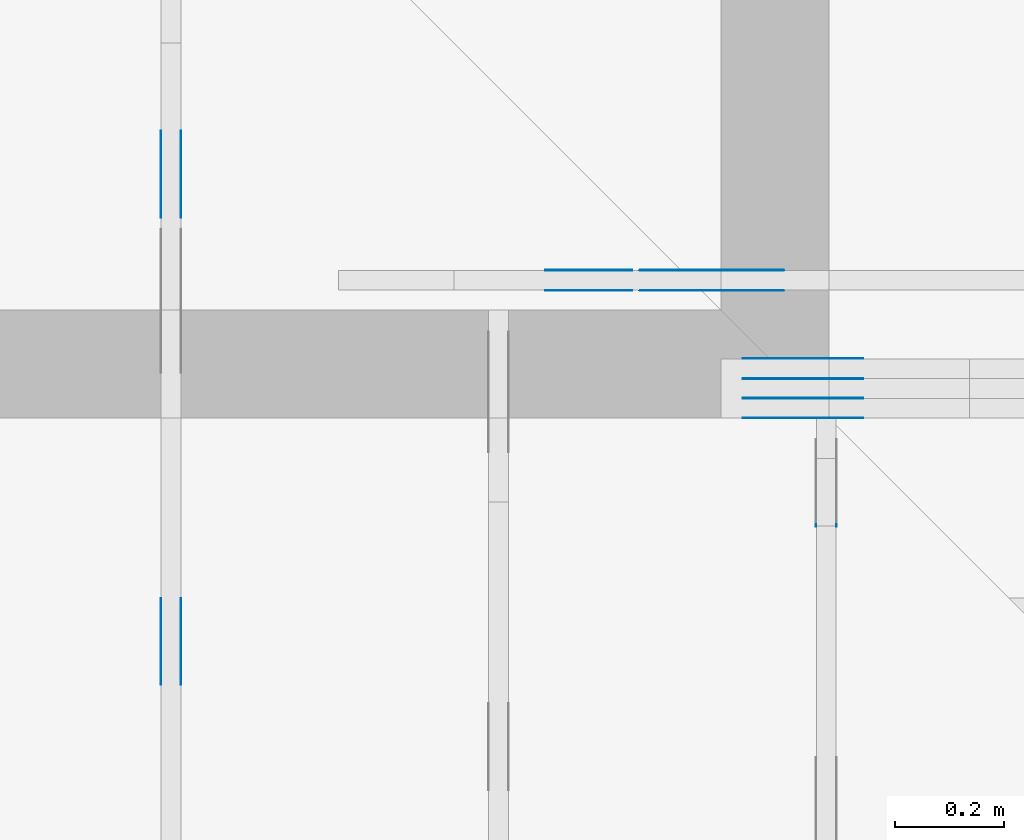
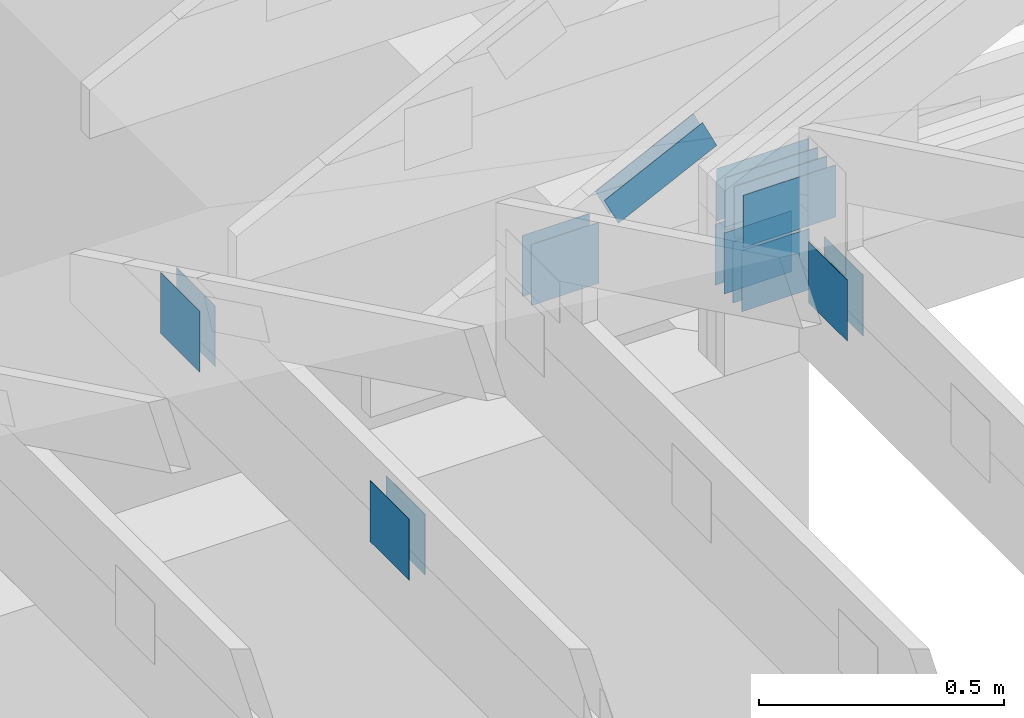
# One storey, part 97 of 159: 22 plates, 4 elements without a shape of their own.
"""IFC2X3 building model written with IfcOpenShell, lengths in millimetres."""

from ifc_helpers import new_model, si_unit, frame, origin, origin_with_axes, origin_2d, place, context, project, spatial, faceted_brep, element, aggregate, save


model = new_model("IFC2X3")

# Units and contexts
model_context = context("Model", 3, precision=1e-05, world=origin())
plan_context = context("Plan", 2, precision=1e-05, world=origin_2d())
ifc_project = project(units=[si_unit("LENGTHUNIT", "METRE", prefix="MILLI"), si_unit("AREAUNIT", "SQUARE_METRE"), si_unit("VOLUMEUNIT", "CUBIC_METRE"), si_unit("SOLIDANGLEUNIT", "STERADIAN"), si_unit("PLANEANGLEUNIT", "RADIAN"), si_unit("MASSUNIT", "GRAM"), si_unit("TIMEUNIT", "SECOND"), si_unit("THERMODYNAMICTEMPERATUREUNIT", "DEGREE_CELSIUS"), si_unit("LUMINOUSINTENSITYUNIT", "LUMEN")], contexts=[model_context, plan_context])

# Site, building, storey
site_placement = place(None, origin_with_axes())
site = spatial("IfcSite", under=ifc_project, at=site_placement, CompositionType="ELEMENT")
building_placement = place(site_placement, origin_with_axes())
building = spatial("IfcBuilding", under=site, at=building_placement, Name="Plan 1", CompositionType="ELEMENT")
storey_placement = place(building_placement, origin_with_axes())
storey = spatial("IfcBuildingStorey", under=building, at=storey_placement, Name="Etasje 1", CompositionType="ELEMENT", Elevation=0.0)

# Assembly, plates
assembly_1_placement = place(storey_placement, frame((10700.012663101485, 8801.999999990367, 0.0), z_axis=(0.0, -1.0, 6.123031769111886e-17), x_axis=(1.0, 0.0, 0.0)))
assembly_1 = element("IfcElementAssembly", 1, at=assembly_1_placement, inside=storey, Name="T8 (1)", AssemblyPlace="FACTORY", PredefinedType="TRUSS")
plate_1_placement = place(assembly_1_placement, frame((43.239723205566406, 306.0, 0.0), z_axis=(0.0, 0.0, 1.0), x_axis=(1.0, 0.0, 0.0)))
plate_1 = element("IfcPlate", 2, at=plate_1_placement, Name="GNT100S 130x218", context=model_context, shape_type="Brep", body=[
    faceted_brep([(217.99999237060547, 130.0, 1.0), (0.0, 130.0, 1.0), (0.0, 0.0, 1.0), (217.99999237060547, 0.0, 1.0), (0.0, 130.0, 0.0), (217.99999237060547, 130.0, 2.6696417579027322e-14), (217.99999237060547, 0.0, 2.6696417579027322e-14), (0.0, 0.0, 0.0), (218.00000187195837, 1.304856284685705e-13, 2.451945301233962e-30), (218.00000187195837, 1.305468587862616e-13, 1.0), (1.8719583749771118e-06, 1.7059148655625335e-13, 1.0), (1.8719583749771118e-06, 1.7053025623856223e-13, 2.1054768666696277e-38), (218.00000187195837, 130.00000000000017, 0.0), (218.00000187195837, 130.00000000000017, 1.0), (218.00000187195837, 1.7053025658242404e-13, 1.0), (218.00000187195837, 1.7053025658242404e-13, 0.0), (1.8719583749771118e-06, 130.00000000000017, 0.0), (1.8719583749771118e-06, 130.00000000000017, 1.0), (218.00000187195837, 130.00000000000017, 1.0), (218.00000187195837, 130.00000000000017, -1.5777218104420236e-30), (1.8719583749771118e-06, 1.7053025658242404e-13, 0.0), (1.8719583750383421e-06, 1.7053025658242404e-13, 1.0), (1.8719583909582247e-06, 130.00000000000017, 1.0), (1.8719583908969944e-06, 130.00000000000017, -9.747794662456535e-31)], [[[0, 1, 2, 3]], [[4, 5, 6, 7]], [[8, 9, 10, 11]], [[12, 13, 14, 15]], [[16, 17, 18, 19]], [[20, 21, 22, 23]]]),
])
plate_2_placement = place(assembly_1_placement, frame((43.239723205566406, 306.0, -37.0), z_axis=(0.0, 0.0, 1.0), x_axis=(1.0, 0.0, 0.0)))
plate_2 = element("IfcPlate", 3, at=plate_2_placement, Name="GNT100S 130x218", context=model_context, shape_type="Brep", body=[
    faceted_brep([(217.99999237060547, 130.0, 1.0), (0.0, 130.0, 1.0), (0.0, 0.0, 1.0), (217.99999237060547, 0.0, 1.0), (0.0, 130.0, 0.0), (217.99999237060547, 130.0, 2.6696417579027322e-14), (217.99999237060547, 0.0, 2.6696417579027322e-14), (0.0, 0.0, 0.0), (218.00000187195837, 1.304856284685705e-13, 2.451945301233962e-30), (218.00000187195837, 1.305468587862616e-13, 1.0), (1.8719583749771118e-06, 1.7059148655625335e-13, 1.0), (1.8719583749771118e-06, 1.7053025623856223e-13, 2.1054768666696277e-38), (218.00000187195837, 130.00000000000017, 0.0), (218.00000187195837, 130.00000000000017, 1.0), (218.00000187195837, 1.7053025658242404e-13, 1.0), (218.00000187195837, 1.7053025658242404e-13, 0.0), (1.8719583749771118e-06, 130.00000000000017, 0.0), (1.8719583749771118e-06, 130.00000000000017, 1.0), (218.00000187195837, 130.00000000000017, 1.0), (218.00000187195837, 130.00000000000017, -1.5777218104420236e-30), (1.8719583749771118e-06, 1.7053025658242404e-13, 0.0), (1.8719583750383421e-06, 1.7053025658242404e-13, 1.0), (1.8719583909582247e-06, 130.00000000000017, 1.0), (1.8719583908969944e-06, 130.00000000000017, -9.747794662456535e-31)], [[[0, 1, 2, 3]], [[4, 5, 6, 7]], [[8, 9, 10, 11]], [[12, 13, 14, 15]], [[16, 17, 18, 19]], [[20, 21, 22, 23]]]),
])
plate_3_placement = place(assembly_1_placement, frame((43.239723205566406, 306.0, -36.0), z_axis=(0.0, 0.0, 1.0), x_axis=(1.0, 0.0, 0.0)))
plate_3 = element("IfcPlate", 4, at=plate_3_placement, Name="GNT100S 130x218", context=model_context, shape_type="Brep", body=[
    faceted_brep([(217.99999237060547, 130.0, 1.0), (0.0, 130.0, 1.0), (0.0, 0.0, 1.0), (217.99999237060547, 0.0, 1.0), (0.0, 130.0, 0.0), (217.99999237060547, 130.0, 2.6696417579027322e-14), (217.99999237060547, 0.0, 2.6696417579027322e-14), (0.0, 0.0, 0.0), (218.00000187195837, 1.304856284685705e-13, 2.451945301233962e-30), (218.00000187195837, 1.305468587862616e-13, 1.0), (1.8719583749771118e-06, 1.7059148655625335e-13, 1.0), (1.8719583749771118e-06, 1.7053025623856223e-13, 2.1054768666696277e-38), (218.00000187195837, 130.00000000000017, 0.0), (218.00000187195837, 130.00000000000017, 1.0), (218.00000187195837, 1.7053025658242404e-13, 1.0), (218.00000187195837, 1.7053025658242404e-13, 0.0), (1.8719583749771118e-06, 130.00000000000017, 0.0), (1.8719583749771118e-06, 130.00000000000017, 1.0), (218.00000187195837, 130.00000000000017, 1.0), (218.00000187195837, 130.00000000000017, -1.5777218104420236e-30), (1.8719583749771118e-06, 1.7053025658242404e-13, 0.0), (1.8719583750383421e-06, 1.7053025658242404e-13, 1.0), (1.8719583909582247e-06, 130.00000000000017, 1.0), (1.8719583908969944e-06, 130.00000000000017, -9.747794662456535e-31)], [[[0, 1, 2, 3]], [[4, 5, 6, 7]], [[8, 9, 10, 11]], [[12, 13, 14, 15]], [[16, 17, 18, 19]], [[20, 21, 22, 23]]]),
])
plate_4_placement = place(assembly_1_placement, frame((43.239723205566406, 306.0, -73.0), z_axis=(0.0, 0.0, 1.0), x_axis=(1.0, 0.0, 0.0)))
plate_4 = element("IfcPlate", 5, at=plate_4_placement, Name="GNT100S 130x218", context=model_context, shape_type="Brep", body=[
    faceted_brep([(217.99999237060547, 130.0, 1.0), (0.0, 130.0, 1.0), (0.0, 0.0, 1.0), (217.99999237060547, 0.0, 1.0), (0.0, 130.0, 0.0), (217.99999237060547, 130.0, 2.6696417579027322e-14), (217.99999237060547, 0.0, 2.6696417579027322e-14), (0.0, 0.0, 0.0), (218.00000187195837, 1.304856284685705e-13, 2.451945301233962e-30), (218.00000187195837, 1.305468587862616e-13, 1.0), (1.8719583749771118e-06, 1.7059148655625335e-13, 1.0), (1.8719583749771118e-06, 1.7053025623856223e-13, 2.1054768666696277e-38), (218.00000187195837, 130.00000000000017, 0.0), (218.00000187195837, 130.00000000000017, 1.0), (218.00000187195837, 1.7053025658242404e-13, 1.0), (218.00000187195837, 1.7053025658242404e-13, 0.0), (1.8719583749771118e-06, 130.00000000000017, 0.0), (1.8719583749771118e-06, 130.00000000000017, 1.0), (218.00000187195837, 130.00000000000017, 1.0), (218.00000187195837, 130.00000000000017, -1.5777218104420236e-30), (1.8719583749771118e-06, 1.7053025658242404e-13, 0.0), (1.8719583750383421e-06, 1.7053025658242404e-13, 1.0), (1.8719583909582247e-06, 130.00000000000017, 1.0), (1.8719583908969944e-06, 130.00000000000017, -9.747794662456535e-31)], [[[0, 1, 2, 3]], [[4, 5, 6, 7]], [[8, 9, 10, 11]], [[12, 13, 14, 15]], [[16, 17, 18, 19]], [[20, 21, 22, 23]]]),
])
plate_5_placement = place(assembly_1_placement, frame((43.239723205566406, 306.0, -72.0), z_axis=(0.0, 0.0, 1.0), x_axis=(1.0, 0.0, 0.0)))
plate_5 = element("IfcPlate", 6, at=plate_5_placement, Name="GNT100S 130x218", context=model_context, shape_type="Brep", body=[
    faceted_brep([(217.99999237060547, 130.0, 1.0), (0.0, 130.0, 1.0), (0.0, 0.0, 1.0), (217.99999237060547, 0.0, 1.0), (0.0, 130.0, 0.0), (217.99999237060547, 130.0, 2.6696417579027322e-14), (217.99999237060547, 0.0, 2.6696417579027322e-14), (0.0, 0.0, 0.0), (218.00000187195837, 1.304856284685705e-13, 2.451945301233962e-30), (218.00000187195837, 1.305468587862616e-13, 1.0), (1.8719583749771118e-06, 1.7059148655625335e-13, 1.0), (1.8719583749771118e-06, 1.7053025623856223e-13, 2.1054768666696277e-38), (218.00000187195837, 130.00000000000017, 0.0), (218.00000187195837, 130.00000000000017, 1.0), (218.00000187195837, 1.7053025658242404e-13, 1.0), (218.00000187195837, 1.7053025658242404e-13, 0.0), (1.8719583749771118e-06, 130.00000000000017, 0.0), (1.8719583749771118e-06, 130.00000000000017, 1.0), (218.00000187195837, 130.00000000000017, 1.0), (218.00000187195837, 130.00000000000017, -1.5777218104420236e-30), (1.8719583749771118e-06, 1.7053025658242404e-13, 0.0), (1.8719583750383421e-06, 1.7053025658242404e-13, 1.0), (1.8719583909582247e-06, 130.00000000000017, 1.0), (1.8719583908969944e-06, 130.00000000000017, -9.747794662456535e-31)], [[[0, 1, 2, 3]], [[4, 5, 6, 7]], [[8, 9, 10, 11]], [[12, 13, 14, 15]], [[16, 17, 18, 19]], [[20, 21, 22, 23]]]),
])
plate_6_placement = place(assembly_1_placement, frame((43.239723205566406, 306.0, -109.0), z_axis=(0.0, 0.0, 1.0), x_axis=(1.0, 0.0, 0.0)))
plate_6 = element("IfcPlate", 7, at=plate_6_placement, Name="GNT100S 130x218", context=model_context, shape_type="Brep", body=[
    faceted_brep([(217.99999237060547, 130.0, 1.0), (0.0, 130.0, 1.0), (0.0, 0.0, 1.0), (217.99999237060547, 0.0, 1.0), (0.0, 130.0, 0.0), (217.99999237060547, 130.0, 2.6696417579027322e-14), (217.99999237060547, 0.0, 2.6696417579027322e-14), (0.0, 0.0, 0.0), (218.00000187195837, 1.304856284685705e-13, 2.451945301233962e-30), (218.00000187195837, 1.305468587862616e-13, 1.0), (1.8719583749771118e-06, 1.7059148655625335e-13, 1.0), (1.8719583749771118e-06, 1.7053025623856223e-13, 2.1054768666696277e-38), (218.00000187195837, 130.00000000000017, 0.0), (218.00000187195837, 130.00000000000017, 1.0), (218.00000187195837, 1.7053025658242404e-13, 1.0), (218.00000187195837, 1.7053025658242404e-13, 0.0), (1.8719583749771118e-06, 130.00000000000017, 0.0), (1.8719583749771118e-06, 130.00000000000017, 1.0), (218.00000187195837, 130.00000000000017, 1.0), (218.00000187195837, 130.00000000000017, -1.5777218104420236e-30), (1.8719583749771118e-06, 1.7053025658242404e-13, 0.0), (1.8719583750383421e-06, 1.7053025658242404e-13, 1.0), (1.8719583909582247e-06, 130.00000000000017, 1.0), (1.8719583908969944e-06, 130.00000000000017, -9.747794662456535e-31)], [[[0, 1, 2, 3]], [[4, 5, 6, 7]], [[8, 9, 10, 11]], [[12, 13, 14, 15]], [[16, 17, 18, 19]], [[20, 21, 22, 23]]]),
])
plate_7_placement = place(assembly_1_placement, frame((40.0, 147.0, 0.0), z_axis=(0.0, 0.0, 1.0), x_axis=(1.0, 0.0, 0.0)))
plate_7 = element("IfcPlate", 8, at=plate_7_placement, Name="GNT100S 152x159", context=model_context, shape_type="Brep", body=[
    faceted_brep([(159.0, 152.0, 1.0), (0.0, 152.0, 1.0), (0.0, 0.0, 1.0), (159.0, 0.0, 1.0), (0.0, 152.0, 0.0), (159.0, 152.0, 1.9471241025775798e-14), (159.0, 0.0, 1.9471241025775798e-14), (0.0, 0.0, 0.0), (159.0, -2.92068615386637e-14, 1.788345410772899e-30), (159.0, -2.914563122097258e-14, 1.0), (1.1247455413666031e-32, 6.123031769111886e-17, 1.0), (0.0, 0.0, 0.0), (159.0, 152.0, 0.0), (159.0, 152.0, 1.0), (159.0, 0.0, 1.0), (159.0, 0.0, 0.0), (0.0, 152.0, 0.0), (-3.7491518045553436e-33, 152.0, 1.0), (159.0, 152.0, 1.0), (159.0, 152.0, 0.0), (0.0, 0.0, 0.0), (6.123031769111886e-17, -7.498303609110687e-33, 1.0), (1.8675246895791253e-14, 152.0, 1.0), (1.8614016578100134e-14, 152.0, -1.1397421485848245e-30)], [[[0, 1, 2, 3]], [[4, 5, 6, 7]], [[8, 9, 10, 11]], [[12, 13, 14, 15]], [[16, 17, 18, 19]], [[20, 21, 22, 23]]]),
])
plate_8_placement = place(assembly_1_placement, frame((40.0, 147.0, -37.0), z_axis=(0.0, 0.0, 1.0), x_axis=(1.0, 0.0, 0.0)))
plate_8 = element("IfcPlate", 9, at=plate_8_placement, Name="GNT100S 152x159", context=model_context, shape_type="Brep", body=[
    faceted_brep([(159.0, 152.0, 1.0), (0.0, 152.0, 1.0), (0.0, 0.0, 1.0), (159.0, 0.0, 1.0), (0.0, 152.0, 0.0), (159.0, 152.0, 1.9471241025775798e-14), (159.0, 0.0, 1.9471241025775798e-14), (0.0, 0.0, 0.0), (159.0, -2.92068615386637e-14, 1.788345410772899e-30), (159.0, -2.914563122097258e-14, 1.0), (1.1247455413666031e-32, 6.123031769111886e-17, 1.0), (0.0, 0.0, 0.0), (159.0, 152.0, 0.0), (159.0, 152.0, 1.0), (159.0, 0.0, 1.0), (159.0, 0.0, 0.0), (0.0, 152.0, 0.0), (-3.7491518045553436e-33, 152.0, 1.0), (159.0, 152.0, 1.0), (159.0, 152.0, 0.0), (0.0, 0.0, 0.0), (6.123031769111886e-17, -7.498303609110687e-33, 1.0), (1.8675246895791253e-14, 152.0, 1.0), (1.8614016578100134e-14, 152.0, -1.1397421485848245e-30)], [[[0, 1, 2, 3]], [[4, 5, 6, 7]], [[8, 9, 10, 11]], [[12, 13, 14, 15]], [[16, 17, 18, 19]], [[20, 21, 22, 23]]]),
])
plate_9_placement = place(assembly_1_placement, frame((40.0, 147.0, -36.0), z_axis=(0.0, 0.0, 1.0), x_axis=(1.0, 0.0, 0.0)))
plate_9 = element("IfcPlate", 10, at=plate_9_placement, Name="GNT100S 152x159", context=model_context, shape_type="Brep", body=[
    faceted_brep([(159.0, 152.0, 1.0), (0.0, 152.0, 1.0), (0.0, 0.0, 1.0), (159.0, 0.0, 1.0), (0.0, 152.0, 0.0), (159.0, 152.0, 1.9471241025775798e-14), (159.0, 0.0, 1.9471241025775798e-14), (0.0, 0.0, 0.0), (159.0, -2.92068615386637e-14, 1.788345410772899e-30), (159.0, -2.914563122097258e-14, 1.0), (1.1247455413666031e-32, 6.123031769111886e-17, 1.0), (0.0, 0.0, 0.0), (159.0, 152.0, 0.0), (159.0, 152.0, 1.0), (159.0, 0.0, 1.0), (159.0, 0.0, 0.0), (0.0, 152.0, 0.0), (-3.7491518045553436e-33, 152.0, 1.0), (159.0, 152.0, 1.0), (159.0, 152.0, 0.0), (0.0, 0.0, 0.0), (6.123031769111886e-17, -7.498303609110687e-33, 1.0), (1.8675246895791253e-14, 152.0, 1.0), (1.8614016578100134e-14, 152.0, -1.1397421485848245e-30)], [[[0, 1, 2, 3]], [[4, 5, 6, 7]], [[8, 9, 10, 11]], [[12, 13, 14, 15]], [[16, 17, 18, 19]], [[20, 21, 22, 23]]]),
])
plate_10_placement = place(assembly_1_placement, frame((40.0, 147.0, -73.0), z_axis=(0.0, 0.0, 1.0), x_axis=(1.0, 0.0, 0.0)))
plate_10 = element("IfcPlate", 11, at=plate_10_placement, Name="GNT100S 152x159", context=model_context, shape_type="Brep", body=[
    faceted_brep([(159.0, 152.0, 1.0), (0.0, 152.0, 1.0), (0.0, 0.0, 1.0), (159.0, 0.0, 1.0), (0.0, 152.0, 0.0), (159.0, 152.0, 1.9471241025775798e-14), (159.0, 0.0, 1.9471241025775798e-14), (0.0, 0.0, 0.0), (159.0, -2.92068615386637e-14, 1.788345410772899e-30), (159.0, -2.914563122097258e-14, 1.0), (1.1247455413666031e-32, 6.123031769111886e-17, 1.0), (0.0, 0.0, 0.0), (159.0, 152.0, 0.0), (159.0, 152.0, 1.0), (159.0, 0.0, 1.0), (159.0, 0.0, 0.0), (0.0, 152.0, 0.0), (-3.7491518045553436e-33, 152.0, 1.0), (159.0, 152.0, 1.0), (159.0, 152.0, 0.0), (0.0, 0.0, 0.0), (6.123031769111886e-17, -7.498303609110687e-33, 1.0), (1.8675246895791253e-14, 152.0, 1.0), (1.8614016578100134e-14, 152.0, -1.1397421485848245e-30)], [[[0, 1, 2, 3]], [[4, 5, 6, 7]], [[8, 9, 10, 11]], [[12, 13, 14, 15]], [[16, 17, 18, 19]], [[20, 21, 22, 23]]]),
])
plate_11_placement = place(assembly_1_placement, frame((40.0, 147.0, -72.0), z_axis=(0.0, 0.0, 1.0), x_axis=(1.0, 0.0, 0.0)))
plate_11 = element("IfcPlate", 12, at=plate_11_placement, Name="GNT100S 152x159", context=model_context, shape_type="Brep", body=[
    faceted_brep([(159.0, 152.0, 1.0), (0.0, 152.0, 1.0), (0.0, 0.0, 1.0), (159.0, 0.0, 1.0), (0.0, 152.0, 0.0), (159.0, 152.0, 1.9471241025775798e-14), (159.0, 0.0, 1.9471241025775798e-14), (0.0, 0.0, 0.0), (159.0, -2.92068615386637e-14, 1.788345410772899e-30), (159.0, -2.914563122097258e-14, 1.0), (1.1247455413666031e-32, 6.123031769111886e-17, 1.0), (0.0, 0.0, 0.0), (159.0, 152.0, 0.0), (159.0, 152.0, 1.0), (159.0, 0.0, 1.0), (159.0, 0.0, 0.0), (0.0, 152.0, 0.0), (-3.7491518045553436e-33, 152.0, 1.0), (159.0, 152.0, 1.0), (159.0, 152.0, 0.0), (0.0, 0.0, 0.0), (6.123031769111886e-17, -7.498303609110687e-33, 1.0), (1.8675246895791253e-14, 152.0, 1.0), (1.8614016578100134e-14, 152.0, -1.1397421485848245e-30)], [[[0, 1, 2, 3]], [[4, 5, 6, 7]], [[8, 9, 10, 11]], [[12, 13, 14, 15]], [[16, 17, 18, 19]], [[20, 21, 22, 23]]]),
])
plate_12_placement = place(assembly_1_placement, frame((40.0, 147.0, -109.0), z_axis=(0.0, 0.0, 1.0), x_axis=(1.0, 0.0, 0.0)))
plate_12 = element("IfcPlate", 13, at=plate_12_placement, Name="GNT100S 152x159", context=model_context, shape_type="Brep", body=[
    faceted_brep([(159.0, 152.0, 1.0), (0.0, 152.0, 1.0), (0.0, 0.0, 1.0), (159.0, 0.0, 1.0), (0.0, 152.0, 0.0), (159.0, 152.0, 1.9471241025775798e-14), (159.0, 0.0, 1.9471241025775798e-14), (0.0, 0.0, 0.0), (159.0, -2.92068615386637e-14, 1.788345410772899e-30), (159.0, -2.914563122097258e-14, 1.0), (1.1247455413666031e-32, 6.123031769111886e-17, 1.0), (0.0, 0.0, 0.0), (159.0, 152.0, 0.0), (159.0, 152.0, 1.0), (159.0, 0.0, 1.0), (159.0, 0.0, 0.0), (0.0, 152.0, 0.0), (-3.7491518045553436e-33, 152.0, 1.0), (159.0, 152.0, 1.0), (159.0, 152.0, 0.0), (0.0, 0.0, 0.0), (6.123031769111886e-17, -7.498303609110687e-33, 1.0), (1.8675246895791253e-14, 152.0, 1.0), (1.8614016578100134e-14, 152.0, -1.1397421485848245e-30)], [[[0, 1, 2, 3]], [[4, 5, 6, 7]], [[8, 9, 10, 11]], [[12, 13, 14, 15]], [[16, 17, 18, 19]], [[20, 21, 22, 23]]]),
])
aggregate(assembly_1, [plate_1, plate_2, plate_3, plate_4, plate_5, plate_6, plate_7, plate_8, plate_9, plate_10, plate_11, plate_12])

assembly_2_placement = place(storey_placement, frame((10000.012663278096, 9072.000080051337, 1.1021457184401395e-15), z_axis=(9.811600543477555e-09, 1.0, 6.123031769111886e-17), x_axis=(-1.0, 9.811600543477555e-09, 0.0)))
assembly_2 = element("IfcElementAssembly", 14, at=assembly_2_placement, inside=storey, Name="T9 (79)", AssemblyPlace="FACTORY", PredefinedType="TRUSS")
plate_13_placement = place(assembly_2_placement, frame((-550.8305576897427, 348.60430483070655, 0.0), z_axis=(0.0, 0.0, 1.0), x_axis=(-0.8987940462991673, 0.4383711467890769, 0.0)))
plate_13 = element("IfcPlate", 15, at=plate_13_placement, Name="GNT100S 76x258", context=model_context, shape_type="Brep", body=[
    faceted_brep([(258.0000043867458, 76.00000888797723, 1.0), (2.3151951268118864e-05, 76.00000888797723, 1.0), (9.698002941149753e-06, 0.0, 1.0), (257.9999909327976, 0.0, 1.0), (2.3151951268118864e-05, 76.00000888797723, 2.8352026626324406e-21), (258.0000043867458, 76.00000888797723, 3.159484446582101e-14), (257.9999909327976, 1.8024312453235325e-05, 3.159484281824196e-14), (9.698002941149753e-06, 1.8024312453235325e-05, 1.187623602112009e-21), (258.0, 1.002135082707505e-05, 2.9018435040726756e-30), (258.0, 1.002135082713628e-05, 1.0), (1.1247455413666031e-32, 1.0021350874528547e-05, 1.0), (0.0, 1.0021350874467316e-05, 0.0), (258.0, 76.00001002135087, -6.310887241768095e-30), (258.0, 76.00001002135087, 1.0), (258.0, 1.0021350874467316e-05, 1.0), (258.0, 1.0021350874467316e-05, 0.0), (2.2737367544323206e-13, 76.0000100213509, 0.0), (2.2737367544323206e-13, 76.0000100213509, 1.0), (258.0000000000001, 76.00001002135089, 1.0), (258.0000000000001, 76.00001002135089, 7.888609052210118e-31), (-6.502375584398905e-21, 1.0021350874467316e-05, 3.981425227797197e-37), (6.122381531553447e-17, 1.0021350874467316e-05, 1.0), (1.7812213184738947e-13, 76.0000100213509, 1.0), (1.7806090152969835e-13, 76.0000100213509, 3.0194368129559885e-30)], [[[0, 1, 2, 3]], [[4, 5, 6, 7]], [[8, 9, 10, 11]], [[12, 13, 14, 15]], [[16, 17, 18, 19]], [[20, 21, 22, 23]]]),
])
plate_14_placement = place(assembly_2_placement, frame((-550.8305576897427, 348.60430483070655, -37.0), z_axis=(0.0, 0.0, 1.0), x_axis=(-0.8987940462991673, 0.4383711467890769, 0.0)))
plate_14 = element("IfcPlate", 16, at=plate_14_placement, Name="GNT100S 76x258", context=model_context, shape_type="Brep", body=[
    faceted_brep([(258.0000043867458, 76.00000888797723, 1.0), (2.3151951268118864e-05, 76.00000888797723, 1.0), (9.698002941149753e-06, 0.0, 1.0), (257.9999909327976, 0.0, 1.0), (2.3151951268118864e-05, 76.00000888797723, 2.8352026626324406e-21), (258.0000043867458, 76.00000888797723, 3.159484446582101e-14), (257.9999909327976, 1.8024312453235325e-05, 3.159484281824196e-14), (9.698002941149753e-06, 1.8024312453235325e-05, 1.187623602112009e-21), (258.0, 1.002135082707505e-05, 2.9018435040726756e-30), (258.0, 1.002135082713628e-05, 1.0), (1.1247455413666031e-32, 1.0021350874528547e-05, 1.0), (0.0, 1.0021350874467316e-05, 0.0), (258.0, 76.00001002135087, -6.310887241768095e-30), (258.0, 76.00001002135087, 1.0), (258.0, 1.0021350874467316e-05, 1.0), (258.0, 1.0021350874467316e-05, 0.0), (2.2737367544323206e-13, 76.0000100213509, 0.0), (2.2737367544323206e-13, 76.0000100213509, 1.0), (258.0000000000001, 76.00001002135089, 1.0), (258.0000000000001, 76.00001002135089, 7.888609052210118e-31), (-6.502375584398905e-21, 1.0021350874467316e-05, 3.981425227797197e-37), (6.122381531553447e-17, 1.0021350874467316e-05, 1.0), (1.7812213184738947e-13, 76.0000100213509, 1.0), (1.7806090152969835e-13, 76.0000100213509, 3.0194368129559885e-30)], [[[0, 1, 2, 3]], [[4, 5, 6, 7]], [[8, 9, 10, 11]], [[12, 13, 14, 15]], [[16, 17, 18, 19]], [[20, 21, 22, 23]]]),
])
plate_15_placement = place(assembly_2_placement, frame((-378.7631114697551, 299.00000000088505, 0.0), z_axis=(0.0, 0.0, 1.0), x_axis=(-1.0, -2.6257918365676924e-13, 0.0)))
plate_15 = element("IfcPlate", 17, at=plate_15_placement, Name="GNT100S 152x159", context=model_context, shape_type="Brep", body=[
    faceted_brep([(159.00001108887852, 152.00000000088508, 1.0), (1.1088878579812445e-05, 152.00000000088508, 1.0), (1.1088838675732404e-05, 8.850520316627808e-10, 1.0), (159.00001108883862, 8.850520316627808e-10, 1.0), (1.1088878579812445e-05, 152.00000000088508, 1.3579511165603179e-21), (159.00001108887852, 152.00000000088508, 1.947124238372691e-14), (159.00001108883862, 8.433289622189477e-10, 1.947124238372202e-14), (1.1088838675732404e-05, 8.433289622189477e-10, 1.3579462298813218e-21), (159.0, -2.92068615386637e-14, 1.788345410772899e-30), (159.0, -2.914563122097258e-14, 1.0), (1.1247455413666031e-32, 6.123031769111886e-17, 1.0), (0.0, 0.0, 0.0), (159.0, 152.0, 0.0), (159.0, 152.0, 1.0), (159.0, 0.0, 1.0), (159.0, 0.0, 0.0), (5.684341886080802e-14, 152.00000000000003, 0.0), (5.684341886080802e-14, 152.00000000000003, 1.0), (159.0, 151.99999999999997, 1.0), (159.0, 151.99999999999997, -1.5777218104420236e-30), (6.310887241768095e-30, -3.575432190102213e-45, -3.864176307262893e-46), (6.123031769112517e-17, -3.469002701143155e-32, 1.0), (8.61768067930008e-14, 152.00000000000003, 1.0), (8.611557647530968e-14, 152.00000000000003, -1.7923435102404404e-30)], [[[0, 1, 2, 3]], [[4, 5, 6, 7]], [[8, 9, 10, 11]], [[12, 13, 14, 15]], [[16, 17, 18, 19]], [[20, 21, 22, 23]]]),
])
plate_16_placement = place(assembly_2_placement, frame((-378.7631114697551, 299.00000000088505, -37.0), z_axis=(0.0, 0.0, 1.0), x_axis=(-1.0, -2.6257918365676924e-13, 0.0)))
plate_16 = element("IfcPlate", 18, at=plate_16_placement, Name="GNT100S 152x159", context=model_context, shape_type="Brep", body=[
    faceted_brep([(159.00001108887852, 152.00000000088508, 1.0), (1.1088878579812445e-05, 152.00000000088508, 1.0), (1.1088838675732404e-05, 8.850520316627808e-10, 1.0), (159.00001108883862, 8.850520316627808e-10, 1.0), (1.1088878579812445e-05, 152.00000000088508, 1.3579511165603179e-21), (159.00001108887852, 152.00000000088508, 1.947124238372691e-14), (159.00001108883862, 8.433289622189477e-10, 1.947124238372202e-14), (1.1088838675732404e-05, 8.433289622189477e-10, 1.3579462298813218e-21), (159.0, -2.92068615386637e-14, 1.788345410772899e-30), (159.0, -2.914563122097258e-14, 1.0), (1.1247455413666031e-32, 6.123031769111886e-17, 1.0), (0.0, 0.0, 0.0), (159.0, 152.0, 0.0), (159.0, 152.0, 1.0), (159.0, 0.0, 1.0), (159.0, 0.0, 0.0), (5.684341886080802e-14, 152.00000000000003, 0.0), (5.684341886080802e-14, 152.00000000000003, 1.0), (159.0, 151.99999999999997, 1.0), (159.0, 151.99999999999997, -1.5777218104420236e-30), (6.310887241768095e-30, -3.575432190102213e-45, -3.864176307262893e-46), (6.123031769112517e-17, -3.469002701143155e-32, 1.0), (8.61768067930008e-14, 152.00000000000003, 1.0), (8.611557647530968e-14, 152.00000000000003, -1.7923435102404404e-30)], [[[0, 1, 2, 3]], [[4, 5, 6, 7]], [[8, 9, 10, 11]], [[12, 13, 14, 15]], [[16, 17, 18, 19]], [[20, 21, 22, 23]]]),
])
aggregate(assembly_2, [plate_13, plate_14, plate_15, plate_16])

assembly_3_placement = place(storey_placement, frame((10875.02226140475, -699.9989301294845, 1.1021457184401395e-15), z_axis=(-1.0, 1.836909530733566e-16, 6.123031769111886e-17), x_axis=(-1.836909530733566e-16, -1.0, 0.0)))
assembly_3 = element("IfcElementAssembly", 19, at=assembly_3_placement, inside=storey, Name="T4 (96)", AssemblyPlace="FACTORY", PredefinedType="TRUSS")
plate_17_placement = place(assembly_3_placement, frame((-9461.9990234375, 147.0, 0.0), z_axis=(0.0, 0.0, 1.0), x_axis=(1.0, 0.0, 0.0)))
plate_17 = element("IfcPlate", 20, at=plate_17_placement, Name="GNT100S 152x159", context=model_context, shape_type="Brep", body=[
    faceted_brep([(159.0, 152.0, 1.0), (0.0, 152.0, 1.0), (0.0, 0.0, 1.0), (159.0, 0.0, 1.0), (0.0, 152.0, 0.0), (159.0, 152.0, 1.9471241025775798e-14), (159.0, 0.0, 1.9471241025775798e-14), (0.0, 0.0, 0.0), (159.00009331759065, -2.9206878680260863e-14, 1.7883464603583392e-30), (159.00009331759065, -2.9145648362569744e-14, 1.0), (9.331759065389633e-05, 6.121317609395314e-17, 1.0), (9.331759065389633e-05, -1.714159716572357e-20, 1.0495854401904369e-36), (159.00009331759065, 152.0, 0.0), (159.00009331759065, 152.0, 1.0), (159.00009331759065, 0.0, 1.0), (159.00009331759065, 0.0, 0.0), (9.331759065389633e-05, 152.0, 0.0), (9.331759065389633e-05, 152.0, 1.0), (159.00009331759065, 152.0, 1.0), (159.00009331759065, 152.0, 0.0), (9.331759065389633e-05, 0.0, 0.0), (9.331759065395756e-05, -7.498303609110687e-33, 1.0), (9.331759067257158e-05, 152.0, 1.0), (9.331759067251035e-05, 152.0, -1.1397420192804459e-30)], [[[0, 1, 2, 3]], [[4, 5, 6, 7]], [[8, 9, 10, 11]], [[12, 13, 14, 15]], [[16, 17, 18, 19]], [[20, 21, 22, 23]]]),
])
plate_18_placement = place(assembly_3_placement, frame((-9461.9990234375, 147.0, -37.0), z_axis=(0.0, 0.0, 1.0), x_axis=(1.0, 0.0, 0.0)))
plate_18 = element("IfcPlate", 21, at=plate_18_placement, Name="GNT100S 152x159", context=model_context, shape_type="Brep", body=[
    faceted_brep([(159.0, 152.0, 1.0), (0.0, 152.0, 1.0), (0.0, 0.0, 1.0), (159.0, 0.0, 1.0), (0.0, 152.0, 0.0), (159.0, 152.0, 1.9471241025775798e-14), (159.0, 0.0, 1.9471241025775798e-14), (0.0, 0.0, 0.0), (159.00009331759065, -2.9206878680260863e-14, 1.7883464603583392e-30), (159.00009331759065, -2.9145648362569744e-14, 1.0), (9.331759065389633e-05, 6.121317609395314e-17, 1.0), (9.331759065389633e-05, -1.714159716572357e-20, 1.0495854401904369e-36), (159.00009331759065, 152.0, 0.0), (159.00009331759065, 152.0, 1.0), (159.00009331759065, 0.0, 1.0), (159.00009331759065, 0.0, 0.0), (9.331759065389633e-05, 152.0, 0.0), (9.331759065389633e-05, 152.0, 1.0), (159.00009331759065, 152.0, 1.0), (159.00009331759065, 152.0, 0.0), (9.331759065389633e-05, 0.0, 0.0), (9.331759065395756e-05, -7.498303609110687e-33, 1.0), (9.331759067257158e-05, 152.0, 1.0), (9.331759067251035e-05, 152.0, -1.1397420192804459e-30)], [[[0, 1, 2, 3]], [[4, 5, 6, 7]], [[8, 9, 10, 11]], [[12, 13, 14, 15]], [[16, 17, 18, 19]], [[20, 21, 22, 23]]]),
])
aggregate(assembly_3, [plate_17, plate_18])

assembly_4_placement = place(storey_placement, frame((9675.022261404752, 9699.99999999999, 1.1021457184401395e-15), z_axis=(-1.0, 1.836909530733566e-16, 6.123031769111886e-17), x_axis=(-1.836909530733566e-16, -1.0, 0.0)))
assembly_4 = element("IfcElementAssembly", 22, at=assembly_4_placement, inside=storey, Name="T2 (94)", AssemblyPlace="FACTORY", PredefinedType="TRUSS")
plate_19_placement = place(assembly_4_placement, frame((1227.851282296476, 147.0, 0.0), z_axis=(0.0, 0.0, 1.0), x_axis=(1.0, 0.0, 0.0)))
plate_19 = element("IfcPlate", 23, at=plate_19_placement, Name="GNT100S 152x159", context=model_context, shape_type="Brep", body=[
    faceted_brep([(159.00003606289897, 152.0, 1.0), (3.6062898971067625e-05, 152.0, 1.0), (3.6062898971067625e-05, 0.0, 1.0), (159.00003606289897, 0.0, 1.0), (3.6062898971067625e-05, 152.0, 4.4162855217223885e-21), (159.00003606289897, 152.0, 1.947124544206132e-14), (159.00003606289897, 0.0, 1.947124544206132e-14), (3.6062898971067625e-05, 0.0, 4.4162855217223885e-21), (159.0, 8.447997618295233e-14, 1.788345410772899e-30), (159.0, 8.454120650064345e-14, 1.0), (1.1247455413666031e-32, 1.1374806803930715e-13, 1.0), (0.0, 1.1368683772161603e-13, 0.0), (159.0, 152.0000000000001, 0.0), (159.0, 152.0000000000001, 1.0), (159.0, 1.1368683772161603e-13, 1.0), (159.0, 1.1368683772161603e-13, 0.0), (4.861730685829017e-63, 152.0000000000001, 0.0), (-3.7491518045553436e-33, 152.0000000000001, 1.0), (159.0, 152.0000000000001, 1.0), (159.0, 152.0000000000001, 0.0), (1.392216238198645e-29, 1.1368683772161603e-13, -8.524584255963745e-46), (6.123031769113279e-17, 1.1368683772161603e-13, 1.0), (1.8675246895791266e-14, 152.0000000000001, 1.0), (1.8614016578100147e-14, 152.0000000000001, -1.1397421485848253e-30)], [[[0, 1, 2, 3]], [[4, 5, 6, 7]], [[8, 9, 10, 11]], [[12, 13, 14, 15]], [[16, 17, 18, 19]], [[20, 21, 22, 23]]]),
])
plate_20_placement = place(assembly_4_placement, frame((1227.851282296476, 147.0, -37.0), z_axis=(0.0, 0.0, 1.0), x_axis=(1.0, 0.0, 0.0)))
plate_20 = element("IfcPlate", 24, at=plate_20_placement, Name="GNT100S 152x159", context=model_context, shape_type="Brep", body=[
    faceted_brep([(159.00003606289897, 152.0, 1.0), (3.6062898971067625e-05, 152.0, 1.0), (3.6062898971067625e-05, 0.0, 1.0), (159.00003606289897, 0.0, 1.0), (3.6062898971067625e-05, 152.0, 4.4162855217223885e-21), (159.00003606289897, 152.0, 1.947124544206132e-14), (159.00003606289897, 0.0, 1.947124544206132e-14), (3.6062898971067625e-05, 0.0, 4.4162855217223885e-21), (159.0, 8.447997618295233e-14, 1.788345410772899e-30), (159.0, 8.454120650064345e-14, 1.0), (1.1247455413666031e-32, 1.1374806803930715e-13, 1.0), (0.0, 1.1368683772161603e-13, 0.0), (159.0, 152.0000000000001, 0.0), (159.0, 152.0000000000001, 1.0), (159.0, 1.1368683772161603e-13, 1.0), (159.0, 1.1368683772161603e-13, 0.0), (4.861730685829017e-63, 152.0000000000001, 0.0), (-3.7491518045553436e-33, 152.0000000000001, 1.0), (159.0, 152.0000000000001, 1.0), (159.0, 152.0000000000001, 0.0), (1.392216238198645e-29, 1.1368683772161603e-13, -8.524584255963745e-46), (6.123031769113279e-17, 1.1368683772161603e-13, 1.0), (1.8675246895791266e-14, 152.0000000000001, 1.0), (1.8614016578100147e-14, 152.0000000000001, -1.1397421485848253e-30)], [[[0, 1, 2, 3]], [[4, 5, 6, 7]], [[8, 9, 10, 11]], [[12, 13, 14, 15]], [[16, 17, 18, 19]], [[20, 21, 22, 23]]]),
])
plate_21_placement = place(assembly_4_placement, frame((372.12651478826456, 147.0, 0.0), z_axis=(0.0, 0.0, 1.0), x_axis=(1.0, 0.0, 0.0)))
plate_21 = element("IfcPlate", 25, at=plate_21_placement, Name="GNT100S 152x159", context=model_context, shape_type="Brep", body=[
    faceted_brep([(159.0000110906417, 152.0, 1.0), (1.109064169213525e-05, 152.0, 1.0), (1.109064169213525e-05, 0.0, 1.0), (159.0000110906417, 0.0, 1.0), (1.109064169213525e-05, 152.0, 1.3581670284156189e-21), (159.0000110906417, 152.0, 1.9471242383942826e-14), (159.0000110906417, 0.0, 1.9471242383942826e-14), (1.109064169213525e-05, 0.0, 1.3581670284156189e-21), (159.0, 1.9816681390456836e-13, 1.788345410772899e-30), (159.0, 1.9822804422225948e-13, 1.0), (1.1247455413666031e-32, 2.274349057609232e-13, 1.0), (0.0, 2.2737367544323206e-13, 0.0), (159.0, 152.00000000000023, 0.0), (159.0, 152.00000000000023, 1.0), (159.0, 2.2737367544323206e-13, 1.0), (159.0, 2.2737367544323206e-13, 0.0), (0.0, 152.00000000000023, 0.0), (-3.7491518045553436e-33, 152.00000000000023, 1.0), (159.0, 152.00000000000023, 1.0), (159.0, 152.00000000000023, 0.0), (2.78443247639729e-29, 2.2737367544323206e-13, -1.704916851192749e-45), (6.123031769114671e-17, 2.2737367544323206e-13, 1.0), (1.8675246895791282e-14, 152.00000000000023, 1.0), (1.8614016578100163e-14, 152.00000000000023, -1.1397421485848262e-30)], [[[0, 1, 2, 3]], [[4, 5, 6, 7]], [[8, 9, 10, 11]], [[12, 13, 14, 15]], [[16, 17, 18, 19]], [[20, 21, 22, 23]]]),
])
plate_22_placement = place(assembly_4_placement, frame((372.12651478826456, 147.0, -37.0), z_axis=(0.0, 0.0, 1.0), x_axis=(1.0, 0.0, 0.0)))
plate_22 = element("IfcPlate", 26, at=plate_22_placement, Name="GNT100S 152x159", context=model_context, shape_type="Brep", body=[
    faceted_brep([(159.0000110906417, 152.0, 1.0), (1.109064169213525e-05, 152.0, 1.0), (1.109064169213525e-05, 0.0, 1.0), (159.0000110906417, 0.0, 1.0), (1.109064169213525e-05, 152.0, 1.3581670284156189e-21), (159.0000110906417, 152.0, 1.9471242383942826e-14), (159.0000110906417, 0.0, 1.9471242383942826e-14), (1.109064169213525e-05, 0.0, 1.3581670284156189e-21), (159.0, 1.9816681390456836e-13, 1.788345410772899e-30), (159.0, 1.9822804422225948e-13, 1.0), (1.1247455413666031e-32, 2.274349057609232e-13, 1.0), (0.0, 2.2737367544323206e-13, 0.0), (159.0, 152.00000000000023, 0.0), (159.0, 152.00000000000023, 1.0), (159.0, 2.2737367544323206e-13, 1.0), (159.0, 2.2737367544323206e-13, 0.0), (0.0, 152.00000000000023, 0.0), (-3.7491518045553436e-33, 152.00000000000023, 1.0), (159.0, 152.00000000000023, 1.0), (159.0, 152.00000000000023, 0.0), (2.78443247639729e-29, 2.2737367544323206e-13, -1.704916851192749e-45), (6.123031769114671e-17, 2.2737367544323206e-13, 1.0), (1.8675246895791282e-14, 152.00000000000023, 1.0), (1.8614016578100163e-14, 152.00000000000023, -1.1397421485848262e-30)], [[[0, 1, 2, 3]], [[4, 5, 6, 7]], [[8, 9, 10, 11]], [[12, 13, 14, 15]], [[16, 17, 18, 19]], [[20, 21, 22, 23]]]),
])
aggregate(assembly_4, [plate_19, plate_20, plate_21, plate_22])

save(model, "model.ifc")
